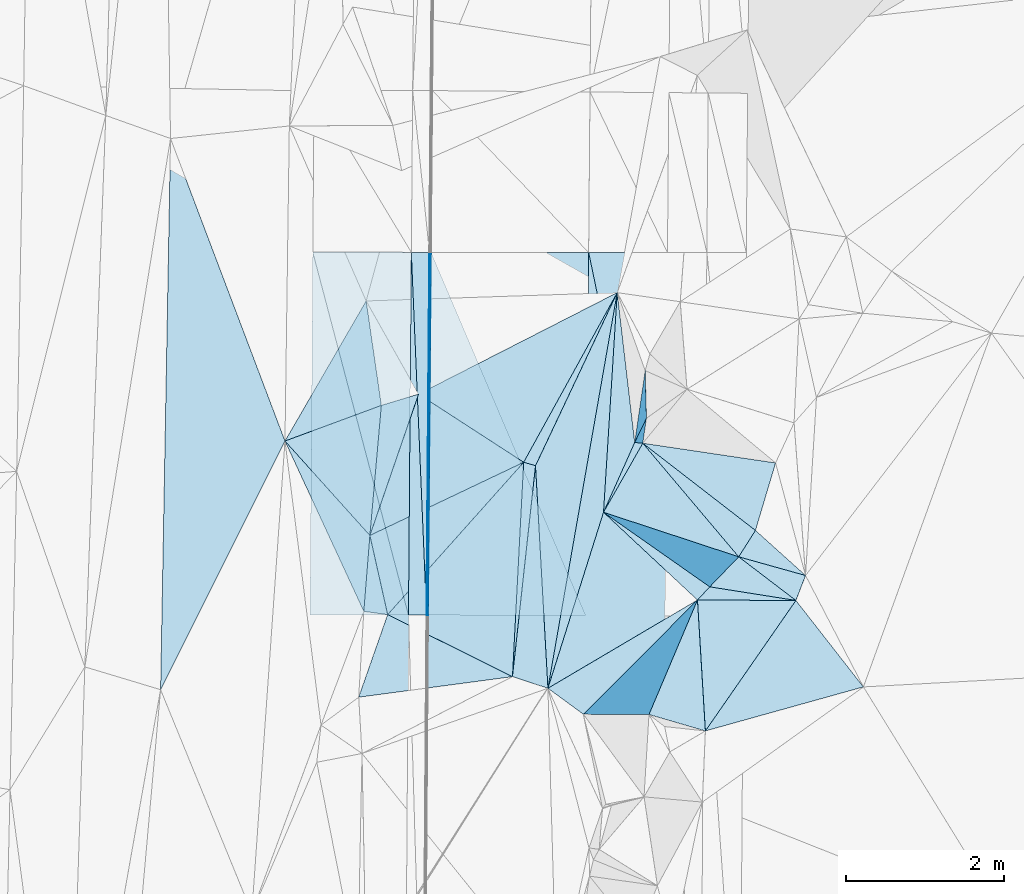
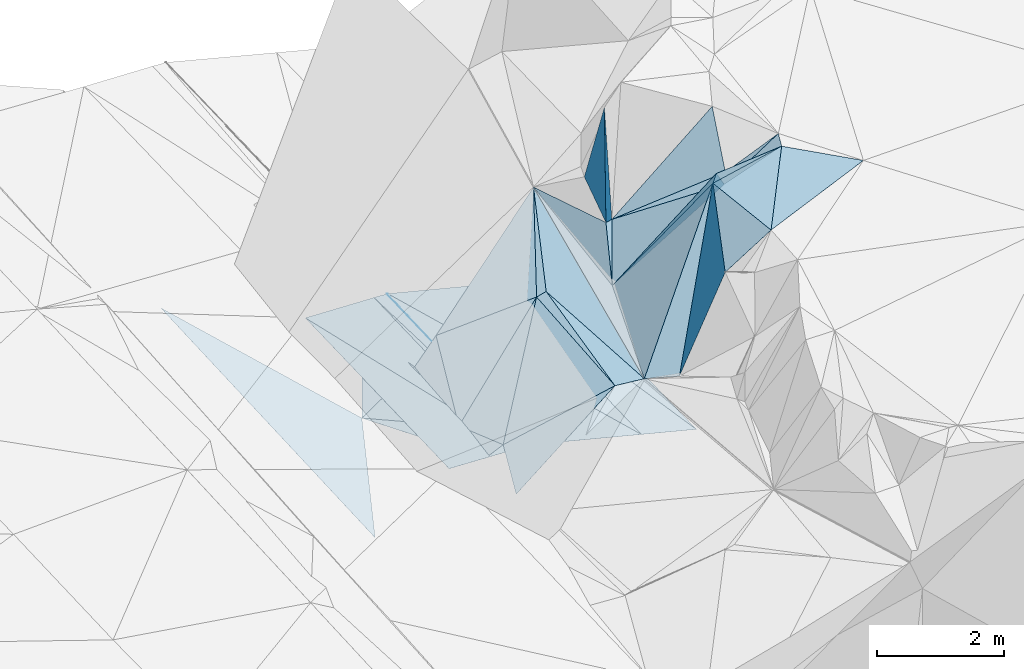
# One storey, part 152 of 275: 45 plates.
"""IFC2X3 building model written with IfcOpenShell, lengths in millimetres."""

import ifcopenshell
import ifcopenshell.guid

model = None  # the IFC model being written
_history = None  # IfcOwnerHistory: only IFC2X3 demands one
_inside = {}  # id of a spatial element -> (the spatial element, [elements in it])
_under = {}  # id of a project, library or spatial element -> (it, [spatial elements below it])
_declared = {}  # id of a project -> (the project, [libraries it declares])
_typed = {}  # id of a type object -> (the type object, [elements of that type])
_made_of = {}  # id of a material, layer set ... -> (it, [elements and type objects made of it])


def new_model(schema):
    """Start an empty IFC model of exactly this schema.

    Asked for "IFC4X3", IfcOpenShell would pick the latest addendum, in which some entities
    have other attributes; the version numbers below select the first issue.
    IFC2X3 requires an IfcOwnerHistory on every rooted entity: one is made here for all.
    """
    global model, _history
    if schema == "IFC4X3":
        model = ifcopenshell.file(schema_version=(4, 3, 0, 0))
    else:
        model = ifcopenshell.file(schema=schema)
    _inside.clear()
    _under.clear()
    _declared.clear()
    _typed.clear()
    _made_of.clear()
    _history = None
    if model.schema == "IFC2X3":
        org = make("IfcOrganization", Name="unknown")
        user = make(
            "IfcPersonAndOrganization",
            ThePerson=make("IfcPerson", FamilyName="unknown"),
            TheOrganization=org,
        )
        app = make(
            "IfcApplication",
            ApplicationDeveloper=org,
            Version="unknown",
            ApplicationFullName="unknown",
            ApplicationIdentifier="unknown",
        )
        _history = make(
            "IfcOwnerHistory",
            OwningUser=user,
            OwningApplication=app,
            ChangeAction="ADDED",
            CreationDate=0,
        )
    return model


def make(cls, **values):
    """One entity of the class cls with the attributes given. An attribute that is None is left unset."""
    return model.create_entity(
        cls, **{name: value for name, value in values.items() if value is not None}
    )


def rooted(cls, **values):
    """An entity with a GlobalId (a new one), such as an element, a storey or a relation."""
    return make(cls, GlobalId=ifcopenshell.guid.new(), OwnerHistory=_history, **values)


def si_unit(unit_type, name, prefix=None):
    """IfcSIUnit, for example si_unit("LENGTHUNIT", "METRE", prefix="MILLI")."""
    return make("IfcSIUnit", UnitType=unit_type, Prefix=prefix, Name=name)


def assignment(units):
    """IfcUnitAssignment: the units of a project."""
    return None if units is None else make("IfcUnitAssignment", Units=units)


def point(xyz):
    """IfcCartesianPoint."""
    return None if xyz is None else make("IfcCartesianPoint", Coordinates=xyz)


def direction(xyz):
    """IfcDirection."""
    return None if xyz is None else make("IfcDirection", DirectionRatios=xyz)


def frame(location, z_axis=None, x_axis=None):
    """IfcAxis2Placement3D, a coordinate frame: its origin and axes. An axis left out is left unset."""
    return make(
        "IfcAxis2Placement3D",
        Location=point(location),
        Axis=direction(z_axis),
        RefDirection=direction(x_axis),
    )


def origin_with_axes():
    """The frame at (0, 0, 0) with the z axis (0, 0, 1) and the x axis (1, 0, 0) written out."""
    return frame((0.0, 0.0, 0.0), z_axis=(0.0, 0.0, 1.0), x_axis=(1.0, 0.0, 0.0))


def place(relative_to, where):
    """IfcLocalPlacement: puts the frame where relative to a parent placement (None: the world)."""
    return make(
        "IfcLocalPlacement", PlacementRelTo=relative_to, RelativePlacement=where
    )


def context(
    kind, dimensions, precision=None, world=None, true_north=None, identifier=None
):
    """IfcGeometricRepresentationContext, for example the 3D "Model" context."""
    return make(
        "IfcGeometricRepresentationContext",
        ContextIdentifier=identifier,
        ContextType=kind,
        CoordinateSpaceDimension=dimensions,
        Precision=precision,
        WorldCoordinateSystem=world,
        TrueNorth=true_north,
    )


def subcontext(parent, identifier, kind, view, scale=None):
    """IfcGeometricRepresentationSubContext, for example "Body" below "Model"."""
    return make(
        "IfcGeometricRepresentationSubContext",
        ContextIdentifier=identifier,
        ContextType=kind,
        ParentContext=parent,
        TargetScale=scale,
        TargetView=view,
    )


def project(units=None, contexts=None):
    """IfcProject with its units and contexts."""
    return rooted(
        "IfcProject",
        Name="project",
        RepresentationContexts=contexts,
        UnitsInContext=assignment(units),
    )


def spatial(cls, under=None, at=None, **own):
    """A site, building, storey or space (cls), placed at a placement, below another one or the project."""
    s = rooted(cls, ObjectPlacement=at, **own)
    if under is not None:
        _under.setdefault(under.id(), (under, []))[1].append(s)
    return s


def polyline(points):
    """IfcPolyline through the points."""
    return make("IfcPolyline", Points=[point(p) for p in points])


def outline(outer, holes=None, kind="AREA"):
    """IfcArbitraryClosedProfileDef: a profile drawn as a closed curve; with holes, ...WithVoids."""
    if holes is None:
        return make("IfcArbitraryClosedProfileDef", ProfileType=kind, OuterCurve=outer)
    return make(
        "IfcArbitraryProfileDefWithVoids",
        ProfileType=kind,
        OuterCurve=outer,
        InnerCurves=holes,
    )


def extrude(swept, where, along, depth):
    """IfcExtrudedAreaSolid: the profile swept, set in the frame where, extruded along a direction by depth."""
    return make(
        "IfcExtrudedAreaSolid",
        SweptArea=swept,
        Position=where,
        ExtrudedDirection=direction(along),
        Depth=depth,
    )


def shape(context_of_items, identifier, shape_type, items):
    """IfcShapeRepresentation: the items that make up one representation, for example the "Body"."""
    return make(
        "IfcShapeRepresentation",
        ContextOfItems=context_of_items,
        RepresentationIdentifier=identifier,
        RepresentationType=shape_type,
        Items=items,
    )


def material(Name=None, Category=None):
    """IfcMaterial."""
    return make("IfcMaterial", Name=Name, Category=Category)


def made_of(thing, what):
    """Note that an element or type object is made of a material, layer set ...; save() writes the relation."""
    if what is not None:
        _made_of.setdefault(what.id(), (what, []))[1].append(thing)
    return thing


def type_object(cls, material=None, **own):
    """A type object (cls), such as IfcWallType, which elements share."""
    return made_of(rooted(cls, **own), material)


def element(
    cls,
    number,
    at=None,
    inside=None,
    cuts=None,
    type_object=None,
    material=None,
    context=None,
    identifier="Body",
    shape_type=None,
    held_by="IfcProductDefinitionShape",
    body=None,
    shapes=None,
    **own,
):
    """One element of the class cls, such as IfcWall. Its Tag is "e" and its number.

    at: its placement. inside: the storey or other place that contains it. cuts: it is an
    opening in that element (IfcRelVoidsElement). A single representation is given by context,
    identifier, shape_type and body (its items); several are given by shapes. held_by: the class
    of the entity that holds the representations. save() writes the other relations.
    """
    e = rooted(cls, Tag="e%d" % number, ObjectPlacement=at, **own)
    if body is not None:
        shapes = [shape(context, identifier, shape_type, body)]
    if shapes is not None:
        e.Representation = make(held_by, Representations=shapes)
    if inside is not None:
        _inside.setdefault(inside.id(), (inside, []))[1].append(e)
    if cuts is not None:
        rooted(
            "IfcRelVoidsElement", RelatingBuildingElement=cuts, RelatedOpeningElement=e
        )
    if type_object is not None:
        _typed.setdefault(type_object.id(), (type_object, []))[1].append(e)
    return made_of(e, material)


def aggregate(whole, parts):
    """IfcRelAggregates: a whole, such as a stair, and the parts it consists of."""
    return rooted("IfcRelAggregates", RelatingObject=whole, RelatedObjects=parts)


def save(model, path):
    """Write the relations noted so far, then the file.

    IfcRelAggregates (storeys below a building ...), IfcRelContainedInSpatialStructure (elements
    in a storey), IfcRelDefinesByType, IfcRelAssociatesMaterial and IfcRelDeclares: one each for
    every whole, place, type object, material and project.
    """
    for whole, parts in _under.values():
        aggregate(whole, parts)
    for where, things in _inside.values():
        rooted(
            "IfcRelContainedInSpatialStructure",
            RelatedElements=things,
            RelatingStructure=where,
        )
    for kind, things in _typed.values():
        rooted("IfcRelDefinesByType", RelatedObjects=things, RelatingType=kind)
    for what, things in _made_of.values():
        rooted("IfcRelAssociatesMaterial", RelatedObjects=things, RelatingMaterial=what)
    for by, libraries in _declared.values():
        rooted("IfcRelDeclares", RelatingContext=by, RelatedDefinitions=libraries)
    model.write(path)


model = new_model("IFC2X3")

# Units and contexts
model_context = context("Model", 3, precision=1e-05, world=origin_with_axes())
body_context = subcontext(model_context, "Body", "Model", "MODEL_VIEW")
ifc_project = project(units=[si_unit("LENGTHUNIT", "METRE", prefix="MILLI"), si_unit("AREAUNIT", "SQUARE_METRE"), si_unit("VOLUMEUNIT", "CUBIC_METRE"), si_unit("MASSUNIT", "GRAM", prefix="KILO"), si_unit("TIMEUNIT", "SECOND"), si_unit("PLANEANGLEUNIT", "RADIAN"), si_unit("SOLIDANGLEUNIT", "STERADIAN"), si_unit("THERMODYNAMICTEMPERATUREUNIT", "DEGREE_CELSIUS"), si_unit("LUMINOUSINTENSITYUNIT", "LUMEN")], contexts=[model_context])

# Site, building, storey
site_placement = place(None, origin_with_axes())
site = spatial("IfcSite", under=ifc_project, at=site_placement, CompositionType="ELEMENT")
building_placement = place(site_placement, origin_with_axes())
building = spatial("IfcBuilding", under=site, at=building_placement, Name="Undefined", CompositionType="ELEMENT")
storey_placement = place(building_placement, origin_with_axes())
storey = spatial("IfcBuildingStorey", under=building, at=storey_placement, Name="Undefined", CompositionType="ELEMENT", Elevation=0.0)

# Plates
ifc_material = material()
plate_type_1 = type_object("IfcPlateType", PredefinedType="NOTDEFINED")
plate_1_placement = place(storey_placement, frame((-53558.6225266462, 132365.874216101, 45075.5601863899), z_axis=(0.46603487537741, -0.0951354710434493, -0.87963670744308), x_axis=(-0.476676996002432, -0.86457250713865, -0.159039056153159)))
element("IfcPlate", 1, at=plate_1_placement, inside=storey, type_object=plate_type_1, material=ifc_material, Name="00", context=body_context, shape_type="SweptSolid", body=[
    extrude(outline(polyline([(0.0, 0.0), (2489.95434570313, -2.73139448836446e-08), (2505.27587890625, 1779.20349121094), (0.0, 0.0)])), frame((-8.85201319254618e-08, 2.18876761149539e-07, -0.5000001331573), z_axis=(0.0, 0.0, 1.0), x_axis=(1.0, 0.0, 0.0)), (0.0, 0.0, 1.0), 1.0),
])
plate_type_2 = type_object("IfcPlateType", PredefinedType="NOTDEFINED")
plate_2_placement = place(storey_placement, frame((-55957.3361739584, 128273.270057889, 43434.5327563937), z_axis=(-0.0497521743304818, 0.0232754695027352, -0.998490347308784), x_axis=(0.003466649876115, 0.999726419466048, 0.0231315490236169)))
element("IfcPlate", 2, at=plate_2_placement, inside=storey, type_object=plate_type_2, material=ifc_material, Name="00_PR", context=body_context, shape_type="SweptSolid", body=[
    extrude(outline(polyline([(0.0, 0.0), (4605.61474609375, 2.0983861759305e-08), (4605.642578125, 20.0252170562744), (0.0, 0.0)])), frame((-8.85201319254618e-08, 2.18876761149539e-07, -0.5000001331573), z_axis=(0.0, 0.0, 1.0), x_axis=(1.0, 0.0, 0.0)), (0.0, 0.0, 1.0), 1.0),
])
plate_3_placement = place(storey_placement, frame((-55977.3354653731, 128273.32079371, 43435.5297560021), z_axis=(-0.0497174855077857, 0.0232753885262964, -0.998492077046049), x_axis=(0.00780895992463087, 0.999706921284504, 0.0229148790255104)))
element("IfcPlate", 3, at=plate_3_placement, inside=storey, type_object=plate_type_2, material=ifc_material, Name="00_PR", context=body_context, shape_type="SweptSolid", body=[
    extrude(outline(polyline([(0.0, 0.0), (4605.65380859375, 2.57350620813668e-08), (0.0826031416654587, 20.0240440368652), (0.0, 0.0)])), frame((-8.85201319254618e-08, 2.18876761149539e-07, -0.5000001331573), z_axis=(0.0, 0.0, 1.0), x_axis=(1.0, 0.0, 0.0)), (0.0, 0.0, 1.0), 1.0),
])
plate_type_3 = type_object("IfcPlateType", PredefinedType="NOTDEFINED")
plate_4_placement = place(storey_placement, frame((-56171.3680358632, 132877.835631647, 43552.5294505601), z_axis=(-0.035441131614839, 0.0231769302230434, -0.99910297572137), x_axis=(-0.0078091289296017, -0.999706941762548, -0.0229139280162808)))
element("IfcPlate", 4, at=plate_4_placement, inside=storey, type_object=plate_type_3, material=ifc_material, Name="00_PR", context=body_context, shape_type="SweptSolid", body=[
    extrude(outline(polyline([(0.0, 0.0), (4605.27783203125, 4.74174157716334e-08), (7.59718418121338, 1250.79772949219), (0.0, 0.0)])), frame((-8.85201319254618e-08, 2.18876761149539e-07, -0.5000001331573), z_axis=(0.0, 0.0, 1.0), x_axis=(1.0, 0.0, 0.0)), (0.0, 0.0, 1.0), 1.0),
])
plate_type_4 = type_object("IfcPlateType", PredefinedType="NOTDEFINED")
plate_5_placement = place(storey_placement, frame((-52921.3876936824, 132874.846371375, 42790.5770499118), z_axis=(-0.242288578748753, 0.0241343513966622, -0.969904004368768), x_axis=(-0.00781204789312918, -0.999706678051868, -0.0229244360064487)))
element("IfcPlate", 5, at=plate_5_placement, inside=storey, type_object=plate_type_4, material=ifc_material, Name="00_PR", context=body_context, shape_type="SweptSolid", body=[
    extrude(outline(polyline([(0.0, 0.0), (4610.58251953125, -5.95537130720913e-08), (1.16437041759491, 1030.76098632813), (0.0, 0.0)])), frame((-8.85201319254618e-08, 2.18876761149539e-07, -0.5000001331573), z_axis=(0.0, 0.0, 1.0), x_axis=(1.0, 0.0, 0.0)), (0.0, 0.0, 1.0), 1.0),
])
plate_type_5 = type_object("IfcPlateType", PredefinedType="NOTDEFINED")
plate_6_placement = place(storey_placement, frame((-55941.3701092442, 132877.624750717, 43541.0677564435), z_axis=(-0.0497371432537817, 0.0232755195719991, -0.998491094987635), x_axis=(-0.00780895991132583, -0.99970692128449, -0.0229148790306746)))
element("IfcPlate", 6, at=plate_6_placement, inside=storey, type_object=plate_type_5, material=ifc_material, Name="00_PR", context=body_context, shape_type="SweptSolid", body=[
    extrude(outline(polyline([(0.0, 0.0), (4605.65380859375, 2.57350620813668e-08), (1.32257986068726, 230.28678894043), (0.0, 0.0)])), frame((-8.85201319254618e-08, 2.18876761149539e-07, -0.5000001331573), z_axis=(0.0, 0.0, 1.0), x_axis=(1.0, 0.0, 0.0)), (0.0, 0.0, 1.0), 1.0),
])
plate_7_placement = place(storey_placement, frame((-56207.3384008209, 128273.907703595, 43447.0047570089), z_axis=(-0.049755954184431, 0.0232747035394847, -0.99849017681615), x_axis=(0.00780912893221215, 0.999706941762573, 0.0229139280142663)))
element("IfcPlate", 7, at=plate_7_placement, inside=storey, type_object=plate_type_5, material=ifc_material, Name="00_PR", context=body_context, shape_type="SweptSolid", body=[
    extrude(outline(polyline([(0.0, 0.0), (4605.27783203125, 4.74174157716334e-08), (0.946445524692535, 230.287796020508), (0.0, 0.0)])), frame((-8.85201319254618e-08, 2.18876761149539e-07, -0.5000001331573), z_axis=(0.0, 0.0, 1.0), x_axis=(1.0, 0.0, 0.0)), (0.0, 0.0, 1.0), 1.0),
])
plate_type_6 = type_object("IfcPlateType", PredefinedType="NOTDEFINED")
plate_8_placement = place(storey_placement, frame((-52440.1567787399, 126804.193360857, 47229.641000759), z_axis=(0.695934671122923, 0.0117644285566976, -0.718008726792205), x_axis=(-0.704436829899729, 0.205336718009666, -0.679415620160325)))
element("IfcPlate", 8, at=plate_8_placement, inside=storey, type_object=plate_type_6, material=ifc_material, Name="00", context=body_context, shape_type="SweptSolid", body=[
    extrude(outline(polyline([(0.0, 0.0), (1015.57867431641, -2.3283064365387e-09), (459.344024658203, 1601.21923828125), (0.0, 0.0)])), frame((-8.85201319254618e-08, 2.18876761149539e-07, -0.5000001331573), z_axis=(0.0, 0.0, 1.0), x_axis=(1.0, 0.0, 0.0)), (0.0, 0.0, 1.0), 1.0),
])
plate_9_placement = place(storey_placement, frame((-51549.1057982125, 130205.012558394, 47239.677420687), z_axis=(0.708612787450779, 0.285751949533316, -0.645146294106342), x_axis=(-0.229982295380693, -0.77085935916697, -0.594040396097872)))
element("IfcPlate", 9, at=plate_9_placement, inside=storey, type_object=plate_type_6, material=ifc_material, Name="00", context=body_context, shape_type="SweptSolid", body=[
    extrude(outline(polyline([(0.0, 0.0), (1111.03552246094, -4.20550350099802e-09), (1228.40356445313, 2102.45678710938), (0.0, 0.0)])), frame((-8.85201319254618e-08, 2.18876761149539e-07, -0.5000001331573), z_axis=(0.0, 0.0, 1.0), x_axis=(1.0, 0.0, 0.0)), (0.0, 0.0, 1.0), 1.0),
])
plate_type_7 = type_object("IfcPlateType", PredefinedType="NOTDEFINED")
plate_10_placement = place(storey_placement, frame((-53957.4151167853, 128268.167963864, 42934.7700517083), z_axis=(-0.242302681207011, 0.0241311373275577, -0.969900561341817), x_axis=(0.00781134288809291, 0.999706756178291, 0.0229212690260301)))
element("IfcPlate", 10, at=plate_10_placement, inside=storey, type_object=plate_type_7, material=ifc_material, Name="00_PR", context=body_context, shape_type="SweptSolid", body=[
    extrude(outline(polyline([(0.0, 0.0), (4608.95068359375, -1.34241417981684e-08), (-0.467100828886032, 1030.76135253906), (0.0, 0.0)])), frame((-8.85201319254618e-08, 2.18876761149539e-07, -0.5000001331573), z_axis=(0.0, 0.0, 1.0), x_axis=(1.0, 0.0, 0.0)), (0.0, 0.0, 1.0), 1.0),
])
plate_type_8 = type_object("IfcPlateType", PredefinedType="NOTDEFINED")
plate_11_placement = place(storey_placement, frame((-53732.5272051282, 129578.824794271, 44929.5654306274), z_axis=(0.290746886947607, 0.400052257948693, -0.869151562525448), x_axis=(0.356423065754104, 0.797728215757394, 0.48640753693068)))
element("IfcPlate", 11, at=plate_11_placement, inside=storey, type_object=plate_type_8, material=ifc_material, Name="00", context=body_context, shape_type="SweptSolid", body=[
    extrude(outline(polyline([(0.0, 0.0), (1110.18017578125, -1.44063960760832e-09), (1153.86682128906, 97.9361038208008), (0.0, 0.0)])), frame((-8.85201319254618e-08, 2.18876761149539e-07, -0.5000001331573), z_axis=(0.0, 0.0, 1.0), x_axis=(1.0, 0.0, 0.0)), (0.0, 0.0, 1.0), 1.0),
])
plate_type_9 = type_object("IfcPlateType", PredefinedType="NOTDEFINED")
plate_12_placement = place(storey_placement, frame((-56696.7518964988, 129284.912609002, 43439.598907887), z_axis=(0.597002057456994, -0.00885000989861082, -0.802190887954302), x_axis=(0.0876624068659992, 0.994671046335016, 0.0542661220769027)))
element("IfcPlate", 12, at=plate_12_placement, inside=storey, type_object=plate_type_9, material=ifc_material, Name="00", context=body_context, shape_type="SweptSolid", body=[
    extrude(outline(polyline([(0.0, 0.0), (1658.49328613281, -4.72937244921923e-09), (1861.38830566406, 570.1171875), (0.0, 0.0)])), frame((-8.85201319254618e-08, 2.18876761149539e-07, -0.5000001331573), z_axis=(0.0, 0.0, 1.0), x_axis=(1.0, 0.0, 0.0)), (0.0, 0.0, 1.0), 1.0),
])
plate_type_10 = type_object("IfcPlateType", PredefinedType="NOTDEFINED")
plate_13_placement = place(storey_placement, frame((-55921.4659969365, 132877.606629766, 43540.0850494898), z_axis=(-0.242288358205417, 0.0241311072350895, -0.969904140181767), x_axis=(0.970181049795882, -0.000892282867957737, -0.242379731925432)))
element("IfcPlate", 13, at=plate_13_placement, inside=storey, type_object=plate_type_10, material=ifc_material, Name="00_PR", context=body_context, shape_type="SweptSolid", body=[
    extrude(outline(polyline([(0.0, 0.0), (2061.525390625, -3.63797880709171e-09), (2056.31396484375, 4608.94775390625), (0.0, 0.0)])), frame((-8.85201319254618e-08, 2.18876761149539e-07, -0.5000001331573), z_axis=(0.0, 0.0, 1.0), x_axis=(1.0, 0.0, 0.0)), (0.0, 0.0, 1.0), 1.0),
])
plate_type_11 = type_object("IfcPlateType", PredefinedType="NOTDEFINED")
plate_14_placement = place(storey_placement, frame((-55921.4659969365, 132877.606629766, 43540.0850494898), z_axis=(-0.242303350755151, 0.0241242495609832, -0.969900565416861), x_axis=(0.389162704924632, -0.913327465486576, -0.119938858939088)))
element("IfcPlate", 14, at=plate_14_placement, inside=storey, type_object=plate_type_11, material=ifc_material, Name="00_PR", context=body_context, shape_type="SweptSolid", body=[
    extrude(outline(polyline([(0.0, 0.0), (5046.86328125, 6.61366357235238e-08), (4203.927734375, 1881.31140136719), (0.0, 0.0)])), frame((-8.85201319254618e-08, 2.18876761149539e-07, -0.5000001331573), z_axis=(0.0, 0.0, 1.0), x_axis=(1.0, 0.0, 0.0)), (0.0, 0.0, 1.0), 1.0),
])
plate_type_12 = type_object("IfcPlateType", PredefinedType="NOTDEFINED")
plate_15_placement = place(storey_placement, frame((-57457.3423058233, 128277.09506661, 43494.502487905), z_axis=(-0.0379037043892388, 0.0225252470618447, -0.999027488329714), x_axis=(0.00780764793502838, 0.999722068777028, 0.0222446810249751)))
element("IfcPlate", 15, at=plate_15_placement, inside=storey, type_object=plate_type_12, material=ifc_material, Name="00_PR", context=body_context, shape_type="SweptSolid", body=[
    extrude(outline(polyline([(0.0, 0.0), (4603.16796875, 8.06903699412942e-09), (5.51620435714722, 1250.90380859375), (0.0, 0.0)])), frame((-8.85201319254618e-08, 2.18876761149539e-07, -0.5000001331573), z_axis=(0.0, 0.0, 1.0), x_axis=(1.0, 0.0, 0.0)), (0.0, 0.0, 1.0), 1.0),
])
plate_type_13 = type_object("IfcPlateType", PredefinedType="NOTDEFINED")
plate_16_placement = place(storey_placement, frame((-53558.4440512504, 132365.910987382, 45075.7161807487), z_axis=(0.822985957448817, -0.021587896064447, -0.567651368874915), x_axis=(0.113509663073188, -0.97287549035404, 0.201565961058405)))
element("IfcPlate", 16, at=plate_16_placement, inside=storey, type_object=plate_type_13, material=ifc_material, Name="00", context=body_context, shape_type="SweptSolid", body=[
    extrude(outline(polyline([(0.0, 0.0), (1954.69506835938, -1.17579475045204e-08), (2662.53442382813, 855.256408691406), (0.0, 0.0)])), frame((-8.85201319254618e-08, 2.18876761149539e-07, -0.5000001331573), z_axis=(0.0, 0.0, 1.0), x_axis=(1.0, 0.0, 0.0)), (0.0, 0.0, 1.0), 1.0),
])
plate_type_14 = type_object("IfcPlateType", PredefinedType="NOTDEFINED")
plate_17_placement = place(storey_placement, frame((-53732.5852469604, 129578.191340245, 44929.7665255571), z_axis=(0.174658953713874, -0.86685890427281, -0.466958124429287), x_axis=(0.693416655852952, -0.228407184003596, 0.68337654311606)))
element("IfcPlate", 17, at=plate_17_placement, inside=storey, type_object=plate_type_14, material=ifc_material, Name="00", context=body_context, shape_type="SweptSolid", body=[
    extrude(outline(polyline([(0.0, 0.0), (2473.01440429688, 7.37782102078199e-09), (2694.88940429688, 745.500854492188), (0.0, 0.0)])), frame((-8.85201319254618e-08, 2.18876761149539e-07, -0.5000001331573), z_axis=(0.0, 0.0, 1.0), x_axis=(1.0, 0.0, 0.0)), (0.0, 0.0, 1.0), 1.0),
])
plate_type_15 = type_object("IfcPlateType", PredefinedType="NOTDEFINED")
plate_18_placement = place(storey_placement, frame((-53732.3517178723, 129578.378860562, 44929.7057663595), z_axis=(0.641718461409006, -0.49182425672128, -0.588477966271821), x_axis=(0.481934987988085, -0.338293530110454, 0.808267378308893)))
element("IfcPlate", 18, at=plate_18_placement, inside=storey, type_object=plate_type_15, material=ifc_material, Name="00", context=body_context, shape_type="SweptSolid", body=[
    extrude(outline(polyline([(0.0, 0.0), (2796.1044921875, 4.99130692332983e-09), (2753.40209960938, 226.44319152832), (0.0, 0.0)])), frame((-8.85201319254618e-08, 2.18876761149539e-07, -0.5000001331573), z_axis=(0.0, 0.0, 1.0), x_axis=(1.0, 0.0, 0.0)), (0.0, 0.0, 1.0), 1.0),
])
plate_type_16 = type_object("IfcPlateType", PredefinedType="NOTDEFINED")
plate_19_placement = place(storey_placement, frame((-51169.1971303615, 128776.323693225, 47449.6499577722), z_axis=(0.561642332627077, -0.440935398696652, -0.700095610882857), x_axis=(-0.700936858655091, 0.196001304941015, -0.685763084920844)))
element("IfcPlate", 19, at=plate_19_placement, inside=storey, type_object=plate_type_16, material=ifc_material, Name="00", context=body_context, shape_type="SweptSolid", body=[
    extrude(outline(polyline([(0.0, 0.0), (1210.33056640625, 1.32422428578138e-09), (1154.14758300781, 394.643463134766), (0.0, 0.0)])), frame((-8.85201319254618e-08, 2.18876761149539e-07, -0.5000001331573), z_axis=(0.0, 0.0, 1.0), x_axis=(1.0, 0.0, 0.0)), (0.0, 0.0, 1.0), 1.0),
])
plate_type_17 = type_object("IfcPlateType", PredefinedType="NOTDEFINED")
plate_20_placement = place(storey_placement, frame((-56078.9812366262, 131077.837671962, 43879.5752891017), z_axis=(0.527016182229288, 0.0268591390705265, -0.849430709544255), x_axis=(0.749456561283221, -0.485957067235302, 0.449622721349348)))
element("IfcPlate", 20, at=plate_20_placement, inside=storey, type_object=plate_type_17, material=ifc_material, Name="00", context=body_context, shape_type="SweptSolid", body=[
    extrude(outline(polyline([(0.0, 0.0), (1779.26953125, -6.21366780251265e-09), (210.423431396484, 1935.33508300781), (0.0, 0.0)])), frame((-8.85201319254618e-08, 2.18876761149539e-07, -0.5000001331573), z_axis=(0.0, 0.0, 1.0), x_axis=(1.0, 0.0, 0.0)), (0.0, 0.0, 1.0), 1.0),
])
plate_type_18 = type_object("IfcPlateType", PredefinedType="NOTDEFINED")
plate_21_placement = place(storey_placement, frame((-53988.2300538402, 127016.655462225, 44829.6698819567), z_axis=(0.527933582318286, 0.534189388127919, -0.660248309556414), x_axis=(-0.795682937022533, 0.582919090897577, -0.164602543110178)))
element("IfcPlate", 21, at=plate_21_placement, inside=storey, type_object=plate_type_18, material=ifc_material, Name="00", context=body_context, shape_type="SweptSolid", body=[
    extrude(outline(polyline([(0.0, 0.0), (564.997375488281, -7.71251507103443e-10), (-690.711181640625, 3024.486328125), (0.0, 0.0)])), frame((-8.85201319254618e-08, 2.18876761149539e-07, -0.5000001331573), z_axis=(0.0, 0.0, 1.0), x_axis=(1.0, 0.0, 0.0)), (0.0, 0.0, 1.0), 1.0),
])
plate_type_19 = type_object("IfcPlateType", PredefinedType="NOTDEFINED")
plate_22_placement = place(storey_placement, frame((-52540.4013208677, 128465.388627704, 47159.7297630575), z_axis=(0.814566016551804, -0.210608218528789, -0.540487171880199), x_axis=(-0.579346386198391, -0.341931557244371, -0.739892272536552)))
element("IfcPlate", 22, at=plate_22_placement, inside=storey, type_object=plate_type_19, material=ifc_material, Name="00", context=body_context, shape_type="SweptSolid", body=[
    extrude(outline(polyline([(0.0, 0.0), (3274.80102539063, -1.666194293648e-08), (1959.84729003906, 1947.17712402344), (0.0, 0.0)])), frame((-8.85201319254618e-08, 2.18876761149539e-07, -0.5000001331573), z_axis=(0.0, 0.0, 1.0), x_axis=(1.0, 0.0, 0.0)), (0.0, 0.0, 1.0), 1.0),
])
plate_type_20 = type_object("IfcPlateType", PredefinedType="NOTDEFINED")
plate_23_placement = place(storey_placement, frame((-52540.3673359497, 128465.398876282, 47159.784954852), z_axis=(0.882535267235792, -0.19011240258916, -0.430103216061943), x_axis=(-0.362877707721805, -0.857050940672649, -0.365764205917823)))
element("IfcPlate", 23, at=plate_23_placement, inside=storey, type_object=plate_type_20, material=ifc_material, Name="00", context=body_context, shape_type="SweptSolid", body=[
    extrude(outline(polyline([(0.0, 0.0), (1695.08117675781, 2.75758793577552e-09), (2619.52075195313, 1662.140625), (0.0, 0.0)])), frame((-8.85201319254618e-08, 2.18876761149539e-07, -0.5000001331573), z_axis=(0.0, 0.0, 1.0), x_axis=(1.0, 0.0, 0.0)), (0.0, 0.0, 1.0), 1.0),
])
plate_type_21 = type_object("IfcPlateType", PredefinedType="NOTDEFINED")
plate_24_placement = place(storey_placement, frame((-52440.4346554279, 126804.201617043, 47229.5051455935), z_axis=(0.140180583117734, 0.0282854462543089, -0.989721848625646), x_axis=(0.566889541948792, 0.817247362055118, 0.103648427113196)))
element("IfcPlate", 24, at=plate_24_placement, inside=storey, type_object=plate_type_21, material=ifc_material, Name="00", context=body_context, shape_type="SweptSolid", body=[
    extrude(outline(polyline([(0.0, 0.0), (2026.07995605469, 1.08993845060468e-08), (1624.41760253906, 1335.9892578125), (0.0, 0.0)])), frame((-8.85201319254618e-08, 2.18876761149539e-07, -0.5000001331573), z_axis=(0.0, 0.0, 1.0), x_axis=(1.0, 0.0, 0.0)), (0.0, 0.0, 1.0), 1.0),
])
plate_type_22 = type_object("IfcPlateType", PredefinedType="NOTDEFINED")
plate_25_placement = place(storey_placement, frame((-52540.6993210761, 128465.4796882, 47159.5123030908), z_axis=(0.218563898287838, -0.0284827202311614, -0.975406867421722), x_axis=(0.675578813720806, 0.725702496813047, 0.130188911090379)))
element("IfcPlate", 25, at=plate_25_placement, inside=storey, type_object=plate_type_22, material=ifc_material, Name="00", context=body_context, shape_type="SweptSolid", body=[
    extrude(outline(polyline([(0.0, 0.0), (230.434371948242, 4.22005541622639e-10), (876.17138671875, 932.965026855469), (0.0, 0.0)])), frame((-8.85201319254618e-08, 2.18876761149539e-07, -0.5000001331573), z_axis=(0.0, 0.0, 1.0), x_axis=(1.0, 0.0, 0.0)), (0.0, 0.0, 1.0), 1.0),
])
plate_type_23 = type_object("IfcPlateType", PredefinedType="NOTDEFINED")
plate_26_placement = place(storey_placement, frame((-52017.5193797618, 129013.65671745, 46619.6364593384), z_axis=(0.647708768143204, -0.227610138830162, -0.727094888148808), x_axis=(0.700936858687765, -0.196001304912266, 0.685763084895663)))
element("IfcPlate", 26, at=plate_26_placement, inside=storey, type_object=plate_type_23, material=ifc_material, Name="00", context=body_context, shape_type="SweptSolid", body=[
    extrude(outline(polyline([(0.0, 0.0), (1210.33056640625, 1.32422428578138e-09), (1179.677734375, 338.172149658203), (0.0, 0.0)])), frame((-8.85201319254618e-08, 2.18876761149539e-07, -0.5000001331573), z_axis=(0.0, 0.0, 1.0), x_axis=(1.0, 0.0, 0.0)), (0.0, 0.0, 1.0), 1.0),
])
plate_type_24 = type_object("IfcPlateType", PredefinedType="NOTDEFINED")
plate_27_placement = place(storey_placement, frame((-54437.9862667216, 127345.757886527, 44736.5049269365), z_axis=(0.13299246393933, 0.0435715439151478, -0.990158838316457), x_axis=(0.172126534949414, 0.982836555126342, 0.0663683800743482)))
element("IfcPlate", 27, at=plate_27_placement, inside=storey, type_object=plate_type_24, material=ifc_material, Name="00", context=body_context, shape_type="SweptSolid", body=[
    extrude(outline(polyline([(0.0, 0.0), (5107.85400390625, 2.85945134237409e-08), (2328.78833007813, 312.004516601563), (0.0, 0.0)])), frame((-8.85201319254618e-08, 2.18876761149539e-07, -0.5000001331573), z_axis=(0.0, 0.0, 1.0), x_axis=(1.0, 0.0, 0.0)), (0.0, 0.0, 1.0), 1.0),
])
plate_type_25 = type_object("IfcPlateType", PredefinedType="NOTDEFINED")
plate_28_placement = place(storey_placement, frame((-53234.092040003, 130454.934038173, 45499.6488100497), z_axis=(0.709788668934704, 0.0533266890229124, -0.702393272810721), x_axis=(0.55464282823394, -0.657006237318878, 0.510601740315039)))
element("IfcPlate", 28, at=plate_28_placement, inside=storey, type_object=plate_type_25, material=ifc_material, Name="00", context=body_context, shape_type="SweptSolid", body=[
    extrude(outline(polyline([(0.0, 0.0), (2193.49047851563, 1.19325704872608e-09), (8.34286785125732, 1157.98547363281), (0.0, 0.0)])), frame((-8.85201319254618e-08, 2.18876761149539e-07, -0.5000001331573), z_axis=(0.0, 0.0, 1.0), x_axis=(1.0, 0.0, 0.0)), (0.0, 0.0, 1.0), 1.0),
])
plate_type_26 = type_object("IfcPlateType", PredefinedType="NOTDEFINED")
plate_29_placement = place(storey_placement, frame((-56743.8954862219, 132259.984473117, 43499.5127477054), z_axis=(0.224087678043585, 0.0104622087625158, -0.974512829436762), x_axis=(0.143580777997656, -0.989385190760933, 0.0223942959822468)))
element("IfcPlate", 29, at=plate_29_placement, inside=storey, type_object=plate_type_26, material=ifc_material, Name="00", context=body_context, shape_type="SweptSolid", body=[
    extrude(outline(polyline([(0.0, 0.0), (1339.62683105469, -6.92671164870262e-09), (1604.84240722656, 1307.90625), (0.0, 0.0)])), frame((-8.85201319254618e-08, 2.18876761149539e-07, -0.5000001331573), z_axis=(0.0, 0.0, 1.0), x_axis=(1.0, 0.0, 0.0)), (0.0, 0.0, 1.0), 1.0),
])
plate_type_27 = type_object("IfcPlateType", PredefinedType="NOTDEFINED")
plate_30_placement = place(storey_placement, frame((-53203.7140880536, 131375.705039599, 45749.9726399887), z_axis=(0.990335481303583, -0.12743754675573, -0.0547293901672705), x_axis=(0.00890666482478036, -0.335357740159768, 0.942048755339464)))
element("IfcPlate", 30, at=plate_30_placement, inside=storey, type_object=plate_type_27, material=ifc_material, Name="00", context=body_context, shape_type="SweptSolid", body=[
    extrude(outline(polyline([(0.0, 0.0), (1804.57751464844, -5.83531800657511e-09), (40.7297554016113, 961.89453125), (0.0, 0.0)])), frame((-8.85201319254618e-08, 2.18876761149539e-07, -0.5000001331573), z_axis=(0.0, 0.0, 1.0), x_axis=(1.0, 0.0, 0.0)), (0.0, 0.0, 1.0), 1.0),
])
plate_type_28 = type_object("IfcPlateType", PredefinedType="NOTDEFINED")
plate_31_placement = place(storey_placement, frame((-54745.5268739359, 130213.165093065, 44679.5575588761), z_axis=(0.465318215052399, -0.0211107866319616, -0.88489168457401), x_axis=(0.855771101053778, -0.244670420041749, 0.455842306239558)))
element("IfcPlate", 31, at=plate_31_placement, inside=storey, type_object=plate_type_28, material=ifc_material, Name="00", context=body_context, shape_type="SweptSolid", body=[
    extrude(outline(polyline([(0.0, 0.0), (175.499282836914, 3.63797880709171e-10), (539.033508300781, 2669.70849609375), (0.0, 0.0)])), frame((-8.85201319254618e-08, 2.18876761149539e-07, -0.5000001331573), z_axis=(0.0, 0.0, 1.0), x_axis=(1.0, 0.0, 0.0)), (0.0, 0.0, 1.0), 1.0),
])
plate_type_29 = type_object("IfcPlateType", PredefinedType="NOTDEFINED")
plate_32_placement = place(storey_placement, frame((-54887.8977512506, 127493.324837306, 44669.5817324804), z_axis=(0.547302058511474, -0.0255812543777566, -0.836544114899844), x_axis=(-0.768059271873313, 0.381725954989067, -0.514169476123507)))
element("IfcPlate", 32, at=plate_32_placement, inside=storey, type_object=plate_type_29, material=ifc_material, Name="00", context=body_context, shape_type="SweptSolid", body=[
    extrude(outline(polyline([(0.0, 0.0), (2061.5771484375, 2.66300048679113e-09), (923.710327148438, 2562.1591796875), (0.0, 0.0)])), frame((-8.85201319254618e-08, 2.18876761149539e-07, -0.5000001331573), z_axis=(0.0, 0.0, 1.0), x_axis=(1.0, 0.0, 0.0)), (0.0, 0.0, 1.0), 1.0),
])
plate_type_30 = type_object("IfcPlateType", PredefinedType="NOTDEFINED")
plate_33_placement = place(storey_placement, frame((-54595.4478042914, 130170.24704981, 44759.5158780541), z_axis=(0.24902015860268, 0.0217721278140167, -0.968253548952931), x_axis=(0.423390545097039, 0.896708296322227, 0.129053003178232)))
element("IfcPlate", 33, at=plate_33_placement, inside=storey, type_object=plate_type_30, material=ifc_material, Name="00", context=body_context, shape_type="SweptSolid", body=[
    extrude(outline(polyline([(0.0, 0.0), (2448.6064453125, -1.11613189801574e-08), (-2469.02856445313, 1380.95617675781), (0.0, 0.0)])), frame((-8.85201319254618e-08, 2.18876761149539e-07, -0.5000001331573), z_axis=(0.0, 0.0, 1.0), x_axis=(1.0, 0.0, 0.0)), (0.0, 0.0, 1.0), 1.0),
])
plate_type_31 = type_object("IfcPlateType", PredefinedType="NOTDEFINED")
plate_34_placement = place(storey_placement, frame((-51804.7879196562, 129348.245021185, 46579.5711120556), z_axis=(0.38108256710977, -0.344932214491813, -0.857786596101152), x_axis=(-0.534000722748262, -0.839508190639389, 0.100345532803976)))
element("IfcPlate", 34, at=plate_34_placement, inside=storey, type_object=plate_type_31, material=ifc_material, Name="00", context=body_context, shape_type="SweptSolid", body=[
    extrude(outline(polyline([(0.0, 0.0), (398.622619628906, -1.45519152283669e-11), (-273.943298339844, 2087.8349609375), (0.0, 0.0)])), frame((-8.85201319254618e-08, 2.18876761149539e-07, -0.5000001331573), z_axis=(0.0, 0.0, 1.0), x_axis=(1.0, 0.0, 0.0)), (0.0, 0.0, 1.0), 1.0),
])
plate_type_32 = type_object("IfcPlateType", PredefinedType="NOTDEFINED")
plate_35_placement = place(storey_placement, frame((-51291.9430594562, 128459.580864813, 47439.7213030646), z_axis=(-0.00370518686858264, -0.830232515710054, -0.557404916957165), x_axis=(-0.963472275494337, 0.152229151054318, -0.220334881312619)))
element("IfcPlate", 35, at=plate_35_placement, inside=storey, type_object=plate_type_32, material=ifc_material, Name="00", context=body_context, shape_type="SweptSolid", body=[
    extrude(outline(polyline([(0.0, 0.0), (1134.63647460938, 6.18456397205591e-10), (964.361694335938, 758.950927734375), (0.0, 0.0)])), frame((-8.85201319254618e-08, 2.18876761149539e-07, -0.5000001331573), z_axis=(0.0, 0.0, 1.0), x_axis=(1.0, 0.0, 0.0)), (0.0, 0.0, 1.0), 1.0),
])
plate_type_33 = type_object("IfcPlateType", PredefinedType="NOTDEFINED")
plate_36_placement = place(storey_placement, frame((-51291.8319209101, 128459.982029339, 47439.5122945371), z_axis=(0.218569901333807, -0.0279034337094717, -0.975422265799869), x_axis=(-0.566889541955242, -0.817247362045456, -0.103648427154104)))
element("IfcPlate", 36, at=plate_36_placement, inside=storey, type_object=plate_type_33, material=ifc_material, Name="00", context=body_context, shape_type="SweptSolid", body=[
    extrude(outline(polyline([(0.0, 0.0), (2026.07995605469, 1.08993845060468e-08), (732.498229980469, 1049.54577636719), (0.0, 0.0)])), frame((-8.85201319254618e-08, 2.18876761149539e-07, -0.5000001331573), z_axis=(0.0, 0.0, 1.0), x_axis=(1.0, 0.0, 0.0)), (0.0, 0.0, 1.0), 1.0),
])
plate_type_34 = type_object("IfcPlateType", PredefinedType="NOTDEFINED")
plate_37_placement = place(storey_placement, frame((-57774.3918149079, 130482.616289005, 43243.5055028122), z_axis=(-0.146109812619662, 0.023565696613491, -0.988987654422121), x_axis=(-0.446990034510342, -0.893418990219276, 0.0447483738700282)))
element("IfcPlate", 37, at=plate_37_placement, inside=storey, type_object=plate_type_34, material=ifc_material, Name="00", context=body_context, shape_type="SweptSolid", body=[
    extrude(outline(polyline([(0.0, 0.0), (3530.8544921875, 9.53150447458029e-09), (-2766.72802734375, 3046.7412109375), (0.0, 0.0)])), frame((-8.85201319254618e-08, 2.18876761149539e-07, -0.5000001331573), z_axis=(0.0, 0.0, 1.0), x_axis=(1.0, 0.0, 0.0)), (0.0, 0.0, 1.0), 1.0),
])
plate_type_35 = type_object("IfcPlateType", PredefinedType="NOTDEFINED")
plate_38_placement = place(storey_placement, frame((-53188.0683519999, 130771.078434734, 47449.9192709521), z_axis=(0.136276487972894, 0.977423241753607, -0.161469889780242), x_axis=(-0.0234372888014606, -0.159763917981347, -0.986876985244304)))
element("IfcPlate", 38, at=plate_38_placement, inside=storey, type_object=plate_type_35, material=ifc_material, Name="00", context=body_context, shape_type="SweptSolid", body=[
    extrude(outline(polyline([(0.0, 0.0), (1975.93017578125, -1.70257408171892e-09), (2006.44738769531, 102.804161071777), (0.0, 0.0)])), frame((-8.85201319254618e-08, 2.18876761149539e-07, -0.5000001331573), z_axis=(0.0, 0.0, 1.0), x_axis=(1.0, 0.0, 0.0)), (0.0, 0.0, 1.0), 1.0),
])
plate_type_36 = type_object("IfcPlateType", PredefinedType="NOTDEFINED")
plate_39_placement = place(storey_placement, frame((-56471.313270577, 128280.284995634, 43609.5802753348), z_axis=(0.543052440446726, -0.0201746955010861, -0.839456388733979), x_axis=(-0.216056009183717, 0.962695015285854, -0.162905213051561)))
element("IfcPlate", 39, at=plate_39_placement, inside=storey, type_object=plate_type_36, material=ifc_material, Name="00", context=body_context, shape_type="SweptSolid", body=[
    extrude(outline(polyline([(0.0, 0.0), (1043.55163574219, -4.10000211559236e-09), (1313.59094238281, 2476.66674804688), (0.0, 0.0)])), frame((-8.85201319254618e-08, 2.18876761149539e-07, -0.5000001331573), z_axis=(0.0, 0.0, 1.0), x_axis=(1.0, 0.0, 0.0)), (0.0, 0.0, 1.0), 1.0),
])
plate_type_37 = type_object("IfcPlateType", PredefinedType="NOTDEFINED")
plate_40_placement = place(storey_placement, frame((-56773.8236735368, 128321.487056931, 43429.5695928861), z_axis=(0.507921254229225, -0.0316743960378844, -0.860820964044119), x_axis=(0.0796937728603516, 0.996765699201578, 0.0103461810573921)))
element("IfcPlate", 40, at=plate_40_placement, inside=storey, type_object=plate_type_37, material=ifc_material, Name="00", context=body_context, shape_type="SweptSolid", body=[
    extrude(outline(polyline([(0.0, 0.0), (966.540222167969, -3.63070284947753e-09), (-15.1054239273071, 354.078826904297), (0.0, 0.0)])), frame((-8.85201319254618e-08, 2.18876761149539e-07, -0.5000001331573), z_axis=(0.0, 0.0, 1.0), x_axis=(1.0, 0.0, 0.0)), (0.0, 0.0, 1.0), 1.0),
])
plate_type_38 = type_object("IfcPlateType", PredefinedType="NOTDEFINED")
plate_41_placement = place(storey_placement, frame((-57774.2108210471, 130482.621573309, 43243.5120645039), z_axis=(0.215617913867776, 0.0342379488791207, -0.975877388853671), x_axis=(0.916172716481655, 0.338673091977292, 0.21430840008074)))
element("IfcPlate", 41, at=plate_41_placement, inside=storey, type_object=plate_type_38, material=ifc_material, Name="00", context=body_context, shape_type="SweptSolid", body=[
    extrude(outline(polyline([(0.0, 0.0), (1334.525390625, -5.67524693906307e-09), (623.343688964844, 1498.27258300781), (0.0, 0.0)])), frame((-8.85201319254618e-08, 2.18876761149539e-07, -0.5000001331573), z_axis=(0.0, 0.0, 1.0), x_axis=(1.0, 0.0, 0.0)), (0.0, 0.0, 1.0), 1.0),
])
plate_type_39 = type_object("IfcPlateType", PredefinedType="NOTDEFINED")
plate_42_placement = place(storey_placement, frame((-53558.6307690343, 132365.879617851, 45075.5553767594), z_axis=(0.449578165990677, -0.0842928927784889, -0.889254845863374), x_axis=(-0.423390544985566, -0.896708296377645, -0.129053003158887)))
element("IfcPlate", 42, at=plate_42_placement, inside=storey, type_object=plate_type_39, material=ifc_material, Name="00", context=body_context, shape_type="SweptSolid", body=[
    extrude(outline(polyline([(0.0, 0.0), (2448.6064453125, -1.11613189801574e-08), (2484.01416015625, 171.890319824219), (0.0, 0.0)])), frame((-8.85201319254618e-08, 2.18876761149539e-07, -0.5000001331573), z_axis=(0.0, 0.0, 1.0), x_axis=(1.0, 0.0, 0.0)), (0.0, 0.0, 1.0), 1.0),
])
plate_type_40 = type_object("IfcPlateType", PredefinedType="NOTDEFINED")
plate_43_placement = place(storey_placement, frame((-56773.9902570945, 128321.501054564, 43429.5077086211), z_axis=(0.174945613619461, -0.00376771353097284, -0.984570889580866), x_axis=(-0.418755144442222, 0.904754353528993, -0.077869690981201)))
element("IfcPlate", 43, at=plate_43_placement, inside=storey, type_object=plate_type_40, material=ifc_material, Name="00", context=body_context, shape_type="SweptSolid", body=[
    extrude(outline(polyline([(0.0, 0.0), (2388.60595703125, 1.00044417195022e-08), (838.618896484375, 480.539642333984), (0.0, 0.0)])), frame((-8.85201319254618e-08, 2.18876761149539e-07, -0.5000001331573), z_axis=(0.0, 0.0, 1.0), x_axis=(1.0, 0.0, 0.0)), (0.0, 0.0, 1.0), 1.0),
])
plate_type_41 = type_object("IfcPlateType", PredefinedType="NOTDEFINED")
plate_44_placement = place(storey_placement, frame((-56471.313530001, 128280.276020887, 43609.5804549502), z_axis=(0.542699404253893, -0.0382264272387841, -0.839056670841146), x_axis=(0.768059272130165, -0.381725954538537, 0.514169476074304)))
element("IfcPlate", 44, at=plate_44_placement, inside=storey, type_object=plate_type_41, material=ifc_material, Name="00", context=body_context, shape_type="SweptSolid", body=[
    extrude(outline(polyline([(0.0, 0.0), (2061.5771484375, 2.66300048679113e-09), (20.0817127227783, 1126.67504882813), (0.0, 0.0)])), frame((-8.85201319254618e-08, 2.18876761149539e-07, -0.5000001331573), z_axis=(0.0, 0.0, 1.0), x_axis=(1.0, 0.0, 0.0)), (0.0, 0.0, 1.0), 1.0),
])
plate_type_42 = type_object("IfcPlateType", PredefinedType="NOTDEFINED")
plate_45_placement = place(storey_placement, frame((-54437.9766554882, 127345.744421089, 44736.5059119736), z_axis=(0.152515404284217, 0.0165522731783089, -0.988162473335561), x_axis=(-0.940851709366611, 0.308521206434604, -0.140045443203493)))
element("IfcPlate", 45, at=plate_45_placement, inside=storey, type_object=plate_type_42, material=ifc_material, Name="00", context=body_context, shape_type="SweptSolid", body=[
    extrude(outline(polyline([(0.0, 0.0), (478.416137695313, 4.65661287307739e-10), (1016.39965820313, 2640.08959960938), (0.0, 0.0)])), frame((-8.85201319254618e-08, 2.18876761149539e-07, -0.5000001331573), z_axis=(0.0, 0.0, 1.0), x_axis=(1.0, 0.0, 0.0)), (0.0, 0.0, 1.0), 1.0),
])

save(model, "model.ifc")
